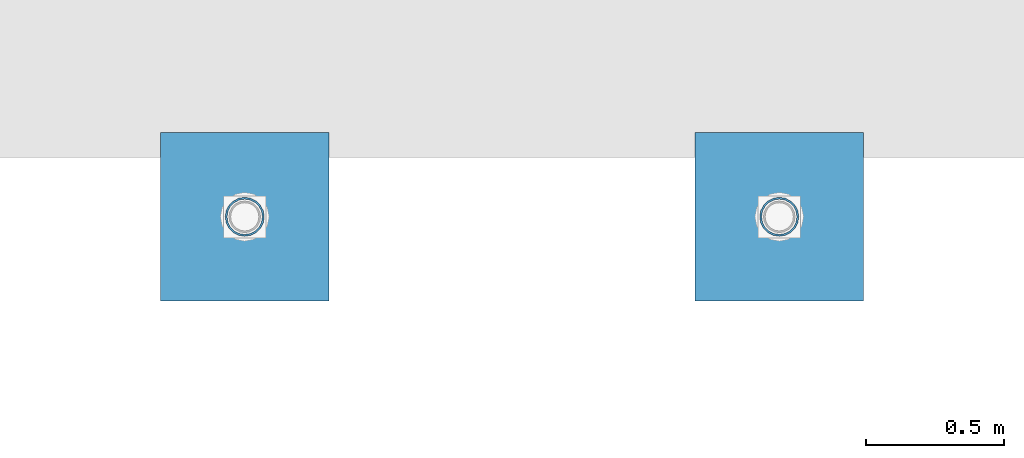
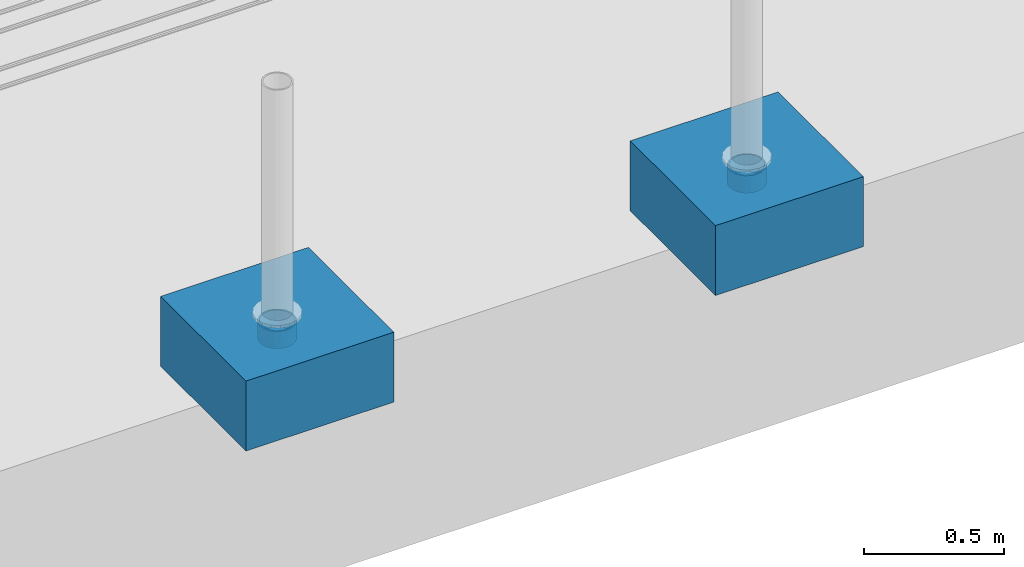
# One storey, part 1560 of 3843: 4 columns, 4 elements without a shape of their own.
"""IFC2X3 building model written with IfcOpenShell, lengths in millimetres."""

from ifc_helpers import new_model, si_unit, frame, origin_with_axes, place, context, subcontext, project, spatial, faceted_brep, material, type_object, element, aggregate, save


model = new_model("IFC2X3")

# Units and contexts
model_context = context("Model", 3, precision=1e-05, world=origin_with_axes())
body_context = subcontext(model_context, "Body", "Model", "MODEL_VIEW")
ifc_project = project(units=[si_unit("LENGTHUNIT", "METRE", prefix="MILLI"), si_unit("AREAUNIT", "SQUARE_METRE"), si_unit("VOLUMEUNIT", "CUBIC_METRE"), si_unit("MASSUNIT", "GRAM", prefix="KILO"), si_unit("TIMEUNIT", "SECOND"), si_unit("PLANEANGLEUNIT", "RADIAN"), si_unit("SOLIDANGLEUNIT", "STERADIAN"), si_unit("THERMODYNAMICTEMPERATUREUNIT", "DEGREE_CELSIUS"), si_unit("LUMINOUSINTENSITYUNIT", "LUMEN")], contexts=[model_context])

# Site, building, storey
site_placement = place(None, origin_with_axes())
site = spatial("IfcSite", under=ifc_project, at=site_placement, CompositionType="ELEMENT")
building_placement = place(site_placement, origin_with_axes())
building = spatial("IfcBuilding", under=site, at=building_placement, Name="Undefined", CompositionType="ELEMENT")
storey_placement = place(building_placement, origin_with_axes())
storey = spatial("IfcBuildingStorey", under=building, at=storey_placement, Name="Undefined", CompositionType="ELEMENT", Elevation=0.0)

# Assembly, column
assembly_1_placement = place(storey_placement, origin_with_axes())
assembly_1 = element("IfcElementAssembly", 1, at=assembly_1_placement, inside=storey, Name="PLATE", AssemblyPlace="NOTDEFINED", PredefinedType="RIGID_FRAME")
ifc_material_1 = material()
column_type_1 = type_object("IfcColumnType", Name="PIPE5SCH40", PredefinedType="NOTDEFINED")
column_1_placement = place(assembly_1_placement, frame((27433.619006902, 86768.0056765079, 30378.4), z_axis=(-1.0, 0.0, 0.0), x_axis=(0.0, 0.0, 1.0)))
column_1 = element("IfcColumn", 2, at=column_1_placement, type_object=column_type_1, material=ifc_material_1, Name="PIPE_SLEEVE", ObjectType="PIPE5SCH40", context=body_context, shape_type="Brep", body=[
    faceted_brep([(0.0, -64.0587999999998, 0.0), (0.0, -60.9235391660477, 19.7952578392724), (76.2000000000007, -60.9235391660477, 19.7952578392724), (76.2000000000007, -64.0587999999998, 0.0), (0.0, -51.8246578392655, 37.6528179195593), (76.2000000000007, -51.8246578392655, 37.6528179195593), (0.0, -37.6528179195529, 51.8246578392718), (76.2000000000007, -37.6528179195529, 51.8246578392718), (0.0, -19.795257839266, 60.9235391660477), (76.2000000000007, -19.795257839266, 60.9235391660477), (0.0, 0.0, 64.0587999999989), (76.2000000000007, 0.0, 64.0587999999989), (0.0, 19.795257839266, 60.9235391660477), (76.2000000000007, 19.795257839266, 60.9235391660477), (0.0, 37.6528179195529, 51.8246578392718), (76.2000000000007, 37.6528179195529, 51.8246578392718), (0.0, 51.8246578392655, 37.6528179195593), (76.2000000000007, 51.8246578392655, 37.6528179195593), (0.0, 60.9235391660477, 19.7952578392724), (76.2000000000007, 60.9235391660477, 19.7952578392724), (0.0, 64.0587999999998, 0.0), (76.2000000000007, 64.0587999999998, 0.0), (0.0, 60.9235391660477, -19.7952578392724), (76.2000000000007, 60.9235391660477, -19.7952578392724), (0.0, 51.8246578392655, -37.6528179195593), (76.2000000000007, 51.8246578392655, -37.6528179195593), (0.0, 37.6528179195529, -51.8246578392718), (76.2000000000007, 37.6528179195529, -51.8246578392718), (0.0, 19.795257839266, -60.9235391660477), (76.2000000000007, 19.795257839266, -60.9235391660477), (0.0, 0.0, -64.0587999999989), (76.2000000000007, 0.0, -64.0587999999989), (0.0, -19.795257839266, -60.9235391660477), (76.2000000000007, -19.795257839266, -60.9235391660477), (0.0, -37.6528179195529, -51.8246578392718), (76.2000000000007, -37.6528179195529, -51.8246578392718), (0.0, -51.8246578392655, -37.6528179195593), (76.2000000000007, -51.8246578392655, -37.6528179195593), (0.0, -60.9235391660477, -19.7952578392724), (76.2000000000007, -60.9235391660477, -19.7952578392724), (0.0, -70.6120000000001, 0.0), (0.0, -67.1560027286332, -21.8203080068051), (76.2000000000007, -67.1560027286332, -21.8203080068051), (76.2000000000007, -70.6120000000001, 0.0), (0.0, -57.1263080068038, -41.5046922348702), (76.2000000000007, -57.1263080068038, -41.5046922348702), (0.0, -41.5046922348765, -57.126308006802), (76.2000000000007, -41.5046922348765, -57.126308006802), (0.0, -21.8203080068042, -67.1560027286323), (76.2000000000007, -21.8203080068042, -67.1560027286323), (0.0, 0.0, -70.6119999999937), (76.2000000000007, 0.0, -70.6119999999937), (0.0, 21.8203080068042, -67.1560027286323), (76.2000000000007, 21.8203080068042, -67.1560027286323), (0.0, 41.5046922348765, -57.126308006802), (76.2000000000007, 41.5046922348765, -57.126308006802), (0.0, 57.1263080068038, -41.5046922348702), (76.2000000000007, 57.1263080068038, -41.5046922348702), (0.0, 67.1560027286332, -21.8203080068051), (76.2000000000007, 67.1560027286332, -21.8203080068051), (0.0, 70.6120000000001, 0.0), (76.2000000000007, 70.6120000000001, 0.0), (0.0, 67.1560027286332, 21.8203080068051), (76.2000000000007, 67.1560027286332, 21.8203080068051), (0.0, 57.1263080068038, 41.5046922348702), (76.2000000000007, 57.1263080068038, 41.5046922348702), (0.0, 41.5046922348765, 57.126308006802), (76.2000000000007, 41.5046922348765, 57.126308006802), (0.0, 21.8203080068042, 67.1560027286323), (76.2000000000007, 21.8203080068042, 67.1560027286323), (0.0, 0.0, 70.6119999999937), (76.2000000000007, 0.0, 70.6119999999937), (0.0, -21.8203080068042, 67.1560027286323), (76.2000000000007, -21.8203080068042, 67.1560027286323), (0.0, -41.5046922348765, 57.126308006802), (76.2000000000007, -41.5046922348765, 57.126308006802), (0.0, -57.1263080068038, 41.5046922348702), (76.2000000000007, -57.1263080068038, 41.5046922348702), (0.0, -67.1560027286332, 21.8203080068051), (76.2000000000007, -67.1560027286332, 21.8203080068051)], [[[0, 1, 2, 3]], [[1, 4, 5, 2]], [[4, 6, 7, 5]], [[6, 8, 9, 7]], [[8, 10, 11, 9]], [[10, 12, 13, 11]], [[12, 14, 15, 13]], [[14, 16, 17, 15]], [[16, 18, 19, 17]], [[18, 20, 21, 19]], [[20, 22, 23, 21]], [[22, 24, 25, 23]], [[24, 26, 27, 25]], [[26, 28, 29, 27]], [[28, 30, 31, 29]], [[30, 32, 33, 31]], [[32, 34, 35, 33]], [[34, 36, 37, 35]], [[36, 38, 39, 37]], [[38, 0, 3, 39]], [[40, 41, 42, 43]], [[41, 44, 45, 42]], [[44, 46, 47, 45]], [[46, 48, 49, 47]], [[48, 50, 51, 49]], [[50, 52, 53, 51]], [[52, 54, 55, 53]], [[54, 56, 57, 55]], [[56, 58, 59, 57]], [[58, 60, 61, 59]], [[60, 62, 63, 61]], [[62, 64, 65, 63]], [[64, 66, 67, 65]], [[66, 68, 69, 67]], [[68, 70, 71, 69]], [[70, 72, 73, 71]], [[72, 74, 75, 73]], [[74, 76, 77, 75]], [[76, 78, 79, 77]], [[78, 40, 43, 79]], [[45, 47, 49, 51, 53, 55, 57, 59, 61, 63, 65, 67, 69, 71, 73, 75, 77, 79, 43, 42], [5, 7, 9, 11, 13, 15, 17, 19, 21, 23, 25, 27, 29, 31, 33, 35, 37, 39, 3, 2]], [[78, 76, 74, 72, 70, 68, 66, 64, 62, 60, 58, 56, 54, 52, 50, 48, 46, 44, 41, 40], [38, 36, 34, 32, 30, 28, 26, 24, 22, 20, 18, 16, 14, 12, 10, 8, 6, 4, 1, 0]]]),
])
aggregate(assembly_1, [column_1])

assembly_2_placement = place(storey_placement, origin_with_axes())
assembly_2 = element("IfcElementAssembly", 3, at=assembly_2_placement, inside=storey, Name="PLATE", AssemblyPlace="NOTDEFINED", PredefinedType="RIGID_FRAME")
column_2_placement = place(assembly_2_placement, frame((25497.8272760212, 86768.0056765079, 30378.4), z_axis=(-1.0, 0.0, 0.0), x_axis=(0.0, 0.0, 1.0)))
column_2 = element("IfcColumn", 4, at=column_2_placement, type_object=column_type_1, material=ifc_material_1, Name="PIPE_SLEEVE", ObjectType="PIPE5SCH40", context=body_context, shape_type="Brep", body=[
    faceted_brep([(0.0, -64.0587999999998, 0.0), (0.0, -60.9235391660477, 19.7952578392724), (76.2000000000007, -60.9235391660477, 19.7952578392724), (76.2000000000007, -64.0587999999998, 0.0), (0.0, -51.8246578392655, 37.6528179195593), (76.2000000000007, -51.8246578392655, 37.6528179195593), (0.0, -37.6528179195529, 51.8246578392718), (76.2000000000007, -37.6528179195529, 51.8246578392718), (0.0, -19.795257839266, 60.9235391660477), (76.2000000000007, -19.795257839266, 60.9235391660477), (0.0, 0.0, 64.0587999999989), (76.2000000000007, 0.0, 64.0587999999989), (0.0, 19.795257839266, 60.9235391660477), (76.2000000000007, 19.795257839266, 60.9235391660477), (0.0, 37.6528179195529, 51.8246578392718), (76.2000000000007, 37.6528179195529, 51.8246578392718), (0.0, 51.8246578392655, 37.6528179195593), (76.2000000000007, 51.8246578392655, 37.6528179195593), (0.0, 60.9235391660477, 19.7952578392724), (76.2000000000007, 60.9235391660477, 19.7952578392724), (0.0, 64.0587999999998, 0.0), (76.2000000000007, 64.0587999999998, 0.0), (0.0, 60.9235391660477, -19.7952578392724), (76.2000000000007, 60.9235391660477, -19.7952578392724), (0.0, 51.8246578392655, -37.6528179195593), (76.2000000000007, 51.8246578392655, -37.6528179195593), (0.0, 37.6528179195529, -51.8246578392718), (76.2000000000007, 37.6528179195529, -51.8246578392718), (0.0, 19.795257839266, -60.9235391660477), (76.2000000000007, 19.795257839266, -60.9235391660477), (0.0, 0.0, -64.0587999999989), (76.2000000000007, 0.0, -64.0587999999989), (0.0, -19.795257839266, -60.9235391660477), (76.2000000000007, -19.795257839266, -60.9235391660477), (0.0, -37.6528179195529, -51.8246578392718), (76.2000000000007, -37.6528179195529, -51.8246578392718), (0.0, -51.8246578392655, -37.6528179195593), (76.2000000000007, -51.8246578392655, -37.6528179195593), (0.0, -60.9235391660477, -19.7952578392724), (76.2000000000007, -60.9235391660477, -19.7952578392724), (0.0, -70.6120000000001, 0.0), (0.0, -67.1560027286332, -21.8203080068051), (76.2000000000007, -67.1560027286332, -21.8203080068051), (76.2000000000007, -70.6120000000001, 0.0), (0.0, -57.1263080068038, -41.5046922348702), (76.2000000000007, -57.1263080068038, -41.5046922348702), (0.0, -41.5046922348765, -57.126308006802), (76.2000000000007, -41.5046922348765, -57.126308006802), (0.0, -21.8203080068042, -67.1560027286323), (76.2000000000007, -21.8203080068042, -67.1560027286323), (0.0, 0.0, -70.6119999999937), (76.2000000000007, 0.0, -70.6119999999937), (0.0, 21.8203080068042, -67.1560027286323), (76.2000000000007, 21.8203080068042, -67.1560027286323), (0.0, 41.5046922348765, -57.126308006802), (76.2000000000007, 41.5046922348765, -57.126308006802), (0.0, 57.1263080068038, -41.5046922348702), (76.2000000000007, 57.1263080068038, -41.5046922348702), (0.0, 67.1560027286332, -21.8203080068051), (76.2000000000007, 67.1560027286332, -21.8203080068051), (0.0, 70.6120000000001, 0.0), (76.2000000000007, 70.6120000000001, 0.0), (0.0, 67.1560027286332, 21.8203080068051), (76.2000000000007, 67.1560027286332, 21.8203080068051), (0.0, 57.1263080068038, 41.5046922348702), (76.2000000000007, 57.1263080068038, 41.5046922348702), (0.0, 41.5046922348765, 57.126308006802), (76.2000000000007, 41.5046922348765, 57.126308006802), (0.0, 21.8203080068042, 67.1560027286323), (76.2000000000007, 21.8203080068042, 67.1560027286323), (0.0, 0.0, 70.6119999999937), (76.2000000000007, 0.0, 70.6119999999937), (0.0, -21.8203080068042, 67.1560027286323), (76.2000000000007, -21.8203080068042, 67.1560027286323), (0.0, -41.5046922348765, 57.126308006802), (76.2000000000007, -41.5046922348765, 57.126308006802), (0.0, -57.1263080068038, 41.5046922348702), (76.2000000000007, -57.1263080068038, 41.5046922348702), (0.0, -67.1560027286332, 21.8203080068051), (76.2000000000007, -67.1560027286332, 21.8203080068051)], [[[0, 1, 2, 3]], [[1, 4, 5, 2]], [[4, 6, 7, 5]], [[6, 8, 9, 7]], [[8, 10, 11, 9]], [[10, 12, 13, 11]], [[12, 14, 15, 13]], [[14, 16, 17, 15]], [[16, 18, 19, 17]], [[18, 20, 21, 19]], [[20, 22, 23, 21]], [[22, 24, 25, 23]], [[24, 26, 27, 25]], [[26, 28, 29, 27]], [[28, 30, 31, 29]], [[30, 32, 33, 31]], [[32, 34, 35, 33]], [[34, 36, 37, 35]], [[36, 38, 39, 37]], [[38, 0, 3, 39]], [[40, 41, 42, 43]], [[41, 44, 45, 42]], [[44, 46, 47, 45]], [[46, 48, 49, 47]], [[48, 50, 51, 49]], [[50, 52, 53, 51]], [[52, 54, 55, 53]], [[54, 56, 57, 55]], [[56, 58, 59, 57]], [[58, 60, 61, 59]], [[60, 62, 63, 61]], [[62, 64, 65, 63]], [[64, 66, 67, 65]], [[66, 68, 69, 67]], [[68, 70, 71, 69]], [[70, 72, 73, 71]], [[72, 74, 75, 73]], [[74, 76, 77, 75]], [[76, 78, 79, 77]], [[78, 40, 43, 79]], [[45, 47, 49, 51, 53, 55, 57, 59, 61, 63, 65, 67, 69, 71, 73, 75, 77, 79, 43, 42], [5, 7, 9, 11, 13, 15, 17, 19, 21, 23, 25, 27, 29, 31, 33, 35, 37, 39, 3, 2]], [[78, 76, 74, 72, 70, 68, 66, 64, 62, 60, 58, 56, 54, 52, 50, 48, 46, 44, 41, 40], [38, 36, 34, 32, 30, 28, 26, 24, 22, 20, 18, 16, 14, 12, 10, 8, 6, 4, 1, 0]]]),
])
aggregate(assembly_2, [column_2])

assembly_3_placement = place(storey_placement, origin_with_axes())
assembly_3 = element("IfcElementAssembly", 5, at=assembly_3_placement, inside=storey, Name="CONC_COL.", AssemblyPlace="NOTDEFINED", PredefinedType="REINFORCEMENT_UNIT")
ifc_material_2 = material(Name="CONCRETE/3000")
column_type_2 = type_object("IfcColumnType", PredefinedType="NOTDEFINED")
column_3_placement = place(assembly_3_placement, frame((27433.619006902, 86768.0056765079, 30175.2), z_axis=(-1.0, 0.0, 0.0), x_axis=(0.0, 0.0, 1.0)))
column_3 = element("IfcColumn", 6, at=column_3_placement, type_object=column_type_2, material=ifc_material_2, Name="CONC_COL.", context=body_context, shape_type="Brep", body=[
    faceted_brep([(0.0, 304.8, -304.800000000003), (0.0, 304.8, 304.800000000003), (304.799999999999, 304.8, 304.800000000003), (304.799999999999, 304.8, -304.800000000003), (0.0, -304.8, 304.800000000003), (304.799999999999, -304.8, 304.800000000003), (0.0, -304.8, -304.800000000003), (304.799999999999, -304.8, -304.800000000003)], [[[0, 1, 2, 3]], [[1, 4, 5, 2]], [[4, 6, 7, 5]], [[6, 0, 3, 7]], [[5, 7, 3, 2]], [[6, 4, 1, 0]]]),
])
aggregate(assembly_3, [column_3])

assembly_4_placement = place(storey_placement, origin_with_axes())
assembly_4 = element("IfcElementAssembly", 7, at=assembly_4_placement, inside=storey, Name="CONC_COL.", AssemblyPlace="NOTDEFINED", PredefinedType="REINFORCEMENT_UNIT")
column_4_placement = place(assembly_4_placement, frame((25497.8272760212, 86768.0056765079, 30175.2), z_axis=(-1.0, 0.0, 0.0), x_axis=(0.0, 0.0, 1.0)))
column_4 = element("IfcColumn", 8, at=column_4_placement, type_object=column_type_2, material=ifc_material_2, Name="CONC_COL.", context=body_context, shape_type="Brep", body=[
    faceted_brep([(0.0, 304.8, -304.800000000003), (0.0, 304.8, 304.800000000003), (304.799999999999, 304.8, 304.800000000003), (304.799999999999, 304.8, -304.800000000003), (0.0, -304.8, 304.800000000003), (304.799999999999, -304.8, 304.800000000003), (0.0, -304.8, -304.800000000003), (304.799999999999, -304.8, -304.800000000003)], [[[0, 1, 2, 3]], [[1, 4, 5, 2]], [[4, 6, 7, 5]], [[6, 0, 3, 7]], [[5, 7, 3, 2]], [[6, 4, 1, 0]]]),
])
aggregate(assembly_4, [column_4])

save(model, "model.ifc")
